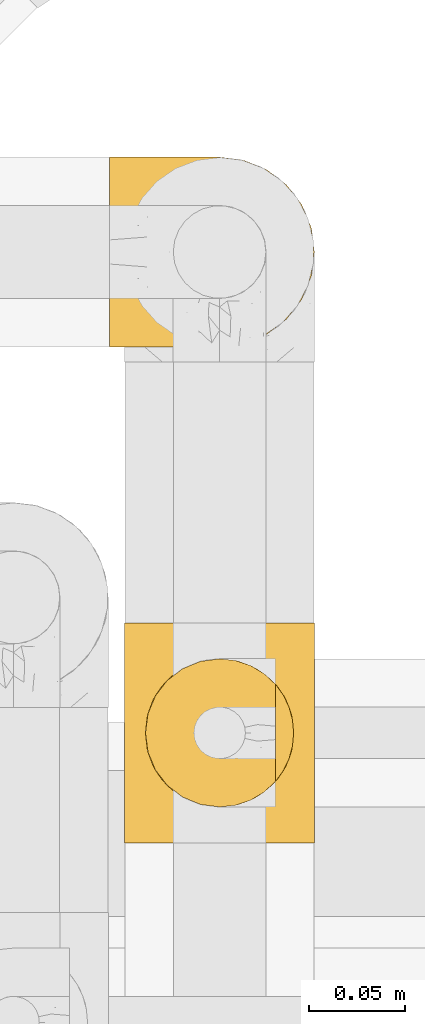
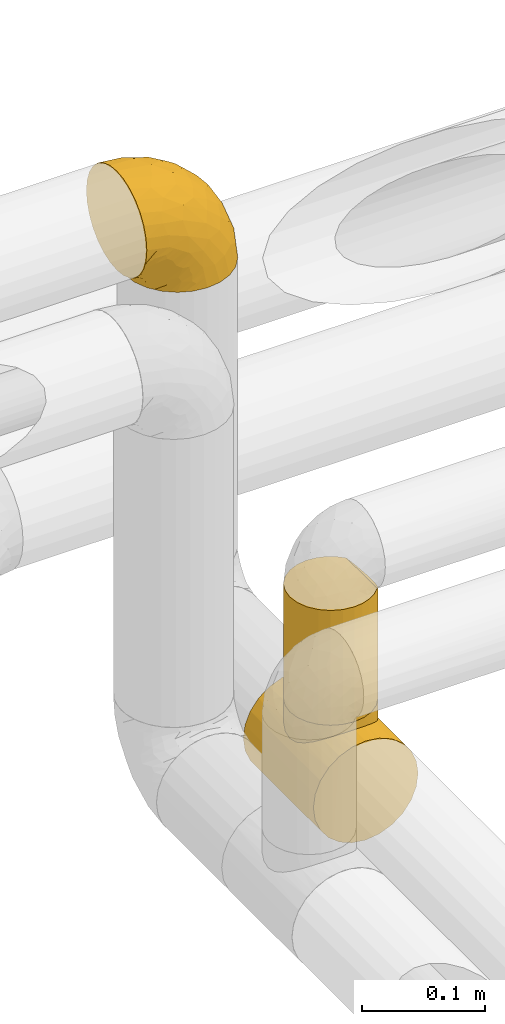
# One storey, part 373 of 827: 3 coverings.
"""IFC2X3 building model written with IfcOpenShell, lengths in millimetres."""

from ifc_helpers import new_model, entity, si_unit, converted_unit, derived_unit, direction, frame, origin, place, context, subcontext, project, spatial, faceted_brep, element, save


model = new_model("IFC2X3")

# Units and contexts
model_context = context("Model", 3, precision=0.01, world=origin(), true_north=direction((6.12303176911189e-17, 1.0)))
body_context = subcontext(model_context, "Body", "Model", "MODEL_VIEW")
ifc_project = project(units=[si_unit("LENGTHUNIT", "METRE", prefix="MILLI"), si_unit("AREAUNIT", "SQUARE_METRE"), si_unit("VOLUMEUNIT", "CUBIC_METRE"), converted_unit("PLANEANGLEUNIT", "DEGREE", entity("IfcRatioMeasure", 0.0174532925199433), si_unit("PLANEANGLEUNIT", "RADIAN"), dimensions=[0, 0, 0, 0, 0, 0, 0]), si_unit("MASSUNIT", "GRAM", prefix="KILO"), derived_unit("MASSDENSITYUNIT", [(si_unit("MASSUNIT", "GRAM", prefix="KILO"), 1), (si_unit("LENGTHUNIT", "METRE"), -3)]), derived_unit("MOMENTOFINERTIAUNIT", [(si_unit("LENGTHUNIT", "METRE"), 4)]), si_unit("TIMEUNIT", "SECOND"), si_unit("FREQUENCYUNIT", "HERTZ"), si_unit("THERMODYNAMICTEMPERATUREUNIT", "DEGREE_CELSIUS"), derived_unit("THERMALTRANSMITTANCEUNIT", [(si_unit("MASSUNIT", "GRAM", prefix="KILO"), 1), (si_unit("THERMODYNAMICTEMPERATUREUNIT", "KELVIN"), -1), (si_unit("TIMEUNIT", "SECOND"), -3)]), derived_unit("VOLUMETRICFLOWRATEUNIT", [(si_unit("LENGTHUNIT", "METRE"), 3), (si_unit("TIMEUNIT", "SECOND"), -1)]), derived_unit("MASSFLOWRATEUNIT", [(si_unit("MASSUNIT", "GRAM", prefix="KILO"), 1), (si_unit("TIMEUNIT", "SECOND"), -1)]), derived_unit("ROTATIONALFREQUENCYUNIT", [(si_unit("TIMEUNIT", "SECOND"), -1)]), si_unit("ELECTRICCURRENTUNIT", "AMPERE"), si_unit("ELECTRICVOLTAGEUNIT", "VOLT"), si_unit("POWERUNIT", "WATT"), si_unit("FORCEUNIT", "NEWTON", prefix="KILO"), si_unit("ILLUMINANCEUNIT", "LUX"), si_unit("LUMINOUSFLUXUNIT", "LUMEN"), si_unit("LUMINOUSINTENSITYUNIT", "CANDELA"), derived_unit("USERDEFINED", [(si_unit("MASSUNIT", "GRAM", prefix="KILO"), -1), (si_unit("LENGTHUNIT", "METRE"), -2), (si_unit("TIMEUNIT", "SECOND"), 3), (si_unit("LUMINOUSFLUXUNIT", "LUMEN"), 1)]), derived_unit("LINEARVELOCITYUNIT", [(si_unit("LENGTHUNIT", "METRE"), 1), (si_unit("TIMEUNIT", "SECOND"), -1)]), si_unit("PRESSUREUNIT", "PASCAL"), derived_unit("USERDEFINED", [(si_unit("LENGTHUNIT", "METRE"), -2), (si_unit("MASSUNIT", "GRAM", prefix="KILO"), 1), (si_unit("TIMEUNIT", "SECOND"), -2)]), derived_unit("LINEARFORCEUNIT", [(si_unit("MASSUNIT", "GRAM", prefix="KILO"), 1), (si_unit("LENGTHUNIT", "METRE"), 1), (si_unit("TIMEUNIT", "SECOND"), -2), (si_unit("LENGTHUNIT", "METRE"), -1)]), derived_unit("PLANARFORCEUNIT", [(si_unit("MASSUNIT", "GRAM", prefix="KILO"), 1), (si_unit("LENGTHUNIT", "METRE"), 1), (si_unit("TIMEUNIT", "SECOND"), -2), (si_unit("LENGTHUNIT", "METRE"), -2)])], contexts=[model_context])

# Site, building, storey
site_placement = place(None, origin())
site = spatial("IfcSite", under=ifc_project, at=site_placement, CompositionType="ELEMENT")
building_placement = place(site_placement, origin())
building = spatial("IfcBuilding", under=site, at=building_placement, CompositionType="ELEMENT")
storey_placement = place(building_placement, frame((0.0, 0.0, 28200.0)))
storey = spatial("IfcBuildingStorey", under=building, at=storey_placement, Name="08", CompositionType="ELEMENT", Elevation=28200.0)

# Coverings
covering_1_placement = place(storey_placement, frame((41417.62, 19064.74, 3341.3)))
element("IfcCovering", 1, at=covering_1_placement, inside=storey, Name=":ADSK_", ObjectType=":ADSK_", PredefinedType="INSULATION", context=body_context, shape_type="Brep", body=[
    faceted_brep([(1.6, 1.6, 58.6), (1.6, 2.83, 69.54), (1.6, 6.47, 79.93), (1.6, 12.32, 89.25), (1.6, 20.11, 97.03), (1.6, 29.43, 102.88), (1.6, 39.81, 106.51), (1.6, 50.75, 107.75), (1.6, 61.69, 106.51), (1.6, 72.08, 102.87), (1.6, 81.4, 97.02), (1.6, 89.18, 89.23), (1.6, 95.03, 79.91), (1.6, 98.66, 69.53), (1.6, 99.9, 58.6), (1.6, 99.25, 52.89), (1.6, 98.66, 47.65), (1.6, 96.84, 42.46), (1.6, 95.02, 37.26), (1.6, 89.17, 27.94), (1.6, 81.38, 20.16), (1.6, 72.06, 14.31), (1.6, 61.68, 10.68), (1.6, 50.75, 9.45), (1.6, 39.8, 10.68), (1.6, 29.41, 14.32), (1.6, 20.09, 20.17), (1.6, 12.31, 27.96), (1.6, 6.46, 37.28), (1.6, 4.64, 42.47), (1.6, 2.83, 47.66), (1.6, 2.24, 52.89), (1.6, 1.92, 55.75), (11.12, 63.47, 1.6), (16.03, 75.32, 1.6), (19.94, 80.41, 1.6), (23.84, 85.5, 1.6), (28.93, 89.4, 1.6), (34.02, 93.31, 1.6), (39.95, 95.77, 1.6), (45.87, 98.22, 1.6), (52.86, 99.14, 1.6), (55.73, 99.52, 1.6), (58.6, 99.9, 1.6), (71.32, 98.22, 1.6), (83.17, 93.31, 1.6), (93.35, 85.5, 1.6), (101.16, 75.32, 1.6), (106.07, 63.47, 1.6), (107.75, 50.75, 1.6), (106.07, 38.02, 1.6), (101.16, 26.17, 1.6), (93.35, 15.99, 1.6), (83.17, 8.18, 1.6), (71.32, 3.27, 1.6), (58.6, 1.6, 1.6), (52.86, 2.35, 1.6), (45.87, 3.27, 1.6), (39.95, 5.73, 1.6), (34.02, 8.18, 1.6), (28.93, 12.09, 1.6), (23.84, 15.99, 1.6), (19.94, 21.08, 1.6), (16.03, 26.17, 1.6), (11.12, 38.02, 1.6), (9.45, 50.75, 1.6), (81.82, 42.18, 69.96), (84.02, 28.42, 59.59), (93.05, 37.78, 51.96), (102.55, 50.75, 34.4), (104.83, 42.85, 23.37), (105.83, 50.75, 13.68), (91.87, 24.75, 41.52), (101.74, 33.81, 26.26), (97.07, 22.57, 20.18), (38.45, 7.18, 72.33), (22.17, 2.73, 65.88), (42.04, 3.09, 57.55), (77.69, 6.92, 23.76), (75.76, 11.58, 46.5), (62.11, 5.17, 46.57), (66.08, 2.71, 21.17), (54.26, 1.6, 23.41), (55.35, 1.6, 17.92), (56.44, 1.6, 12.43), (56.98, 1.6, 9.72), (57.52, 1.6, 7.01), (87.84, 14.18, 26.77), (19.41, 5.88, 76.59), (48.89, 41.06, 95.55), (26.34, 36.25, 102.57), (44.55, 28.62, 92.89), (23.41, 1.6, 54.26), (28.03, 1.6, 51.17), (32.65, 1.6, 48.08), (37.28, 1.6, 44.99), (41.9, 1.6, 41.9), (20.6, 10.85, 85.16), (63.36, 38.35, 85.97), (62.21, 9.6, 59.58), (19.94, 26.24, 99.5), (13.68, 50.75, 105.83), (80.85, 19.31, 53.59), (66.53, 16.41, 67.0), (71.06, 24.56, 71.56), (63.99, 50.75, 87.47), (75.73, 50.75, 75.73), (26.77, 18.47, 92.24), (4.31, 1.6, 58.06), (7.01, 1.6, 57.52), (12.43, 1.6, 56.44), (17.92, 1.6, 55.35), (43.43, 14.36, 81.33), (56.23, 20.64, 80.35), (54.97, 2.32, 39.44), (34.4, 50.75, 102.55), (44.99, 1.6, 37.28), (48.08, 1.6, 32.65), (51.17, 1.6, 28.03), (87.47, 50.75, 63.99), (74.55, 33.88, 74.55), (60.86, 29.24, 83.62), (49.19, 50.75, 95.01), (95.01, 50.75, 49.19), (10.27, 2.8, 46.96), (48.79, 2.48, 8.77), (45.16, 2.7, 18.28), (44.99, 3.2, 11.68), (6.17, 32.98, 11.79), (7.65, 24.67, 15.69), (21.59, 2.95, 42.49), (19.96, 2.19, 47.41), (21.0, 17.92, 7.94), (27.2, 12.02, 9.27), (14.83, 25.73, 7.98), (19.7, 16.63, 13.4), (10.93, 25.6, 13.04), (9.63, 36.72, 7.36), (19.97, 10.66, 23.46), (21.13, 6.87, 30.46), (14.14, 11.12, 26.54), (30.2, 10.31, 6.76), (8.12, 12.84, 26.46), (9.93, 17.38, 20.77), (24.62, 9.74, 20.68), (11.87, 4.63, 40.26), (7.15, 50.75, 7.15), (5.32, 42.52, 9.28), (26.68, 3.12, 38.78), (13.92, 17.58, 18.27), (30.67, 3.97, 31.78), (36.65, 5.94, 12.75), (42.89, 2.73, 22.96), (34.04, 6.23, 17.55), (36.6, 3.45, 27.63), (26.41, 10.84, 15.23), (10.07, 7.98, 33.25), (15.83, 7.33, 32.43), (41.99, 2.39, 27.9), (14.83, 75.76, 7.97), (26.4, 90.65, 15.22), (21.01, 83.57, 7.93), (19.71, 84.85, 13.38), (5.72, 71.05, 13.12), (21.6, 98.54, 42.49), (19.96, 99.3, 47.4), (28.03, 99.9, 51.17), (11.87, 96.86, 40.24), (9.93, 84.1, 20.76), (58.06, 99.9, 4.31), (56.44, 99.9, 12.43), (57.52, 99.9, 7.01), (8.13, 88.63, 26.44), (14.15, 90.36, 26.52), (44.99, 98.29, 11.68), (36.65, 95.55, 12.75), (27.21, 89.47, 9.27), (34.04, 95.26, 17.55), (30.2, 91.18, 6.76), (10.06, 93.49, 33.21), (15.83, 94.15, 32.41), (48.79, 99.01, 8.77), (42.89, 98.76, 22.96), (45.38, 98.85, 18.48), (12.43, 99.9, 56.44), (10.28, 98.69, 46.95), (9.64, 64.78, 7.36), (55.35, 99.9, 17.92), (54.26, 99.9, 23.41), (6.05, 62.91, 9.85), (7.01, 99.9, 57.52), (9.72, 99.9, 56.98), (32.65, 99.9, 48.08), (26.68, 98.37, 38.78), (13.92, 83.9, 18.25), (37.28, 99.9, 44.99), (30.66, 97.51, 31.74), (21.14, 94.62, 30.45), (36.59, 98.04, 27.63), (24.6, 91.73, 20.65), (17.92, 99.9, 55.35), (23.41, 99.9, 54.26), (10.93, 75.87, 13.03), (19.97, 90.83, 23.44), (41.99, 99.1, 27.9), (48.08, 99.9, 32.65), (51.17, 99.9, 28.03), (44.99, 99.9, 37.28), (41.9, 99.9, 41.9), (55.26, 99.09, 39.74), (104.83, 58.64, 23.37), (87.84, 87.31, 26.77), (75.91, 89.93, 46.18), (80.84, 82.22, 53.54), (91.87, 76.74, 41.53), (83.98, 73.12, 59.61), (19.16, 95.54, 76.79), (22.37, 98.7, 66.11), (66.08, 98.79, 21.17), (93.05, 63.71, 51.96), (101.74, 67.68, 26.26), (97.07, 78.92, 20.18), (77.69, 94.57, 23.76), (44.55, 72.88, 92.88), (26.34, 65.25, 102.57), (48.9, 60.44, 95.54), (70.99, 76.94, 71.63), (74.55, 67.61, 74.55), (37.8, 94.38, 72.51), (63.4, 63.11, 85.95), (81.82, 59.31, 69.96), (26.77, 83.03, 92.23), (20.6, 90.66, 85.15), (56.15, 80.8, 80.45), (60.85, 72.22, 83.65), (42.06, 98.39, 57.57), (57.03, 92.31, 63.68), (19.94, 75.27, 99.49), (43.59, 87.15, 81.23), (62.61, 96.03, 47.07), (66.52, 85.1, 66.99)], [[[0, 1, 2, 3, 4, 5, 6, 7, 8, 9, 10, 11, 12, 13, 14, 15, 16, 17, 18, 19, 20, 21, 22, 23, 24, 25, 26, 27, 28, 29, 30, 31, 32]], [[33, 34, 35, 36, 37, 38, 39, 40, 41, 42, 43, 44, 45, 46, 47, 48, 49, 50, 51, 52, 53, 54, 55, 56, 57, 58, 59, 60, 61, 62, 63, 64, 65]], [[66, 67, 68]], [[69, 70, 71]], [[68, 72, 73]], [[73, 72, 74]], [[75, 76, 77]], [[78, 79, 80]], [[51, 50, 73]], [[81, 82, 83, 84, 85, 86, 55]], [[52, 87, 53]], [[74, 52, 51]], [[2, 1, 88]], [[89, 90, 91]], [[77, 92, 93, 94, 95, 96]], [[55, 54, 81]], [[78, 53, 87]], [[5, 90, 6]], [[88, 76, 75]], [[97, 3, 2]], [[89, 91, 98]], [[99, 80, 79]], [[90, 5, 100]], [[74, 87, 52]], [[100, 5, 4]], [[90, 101, 6]], [[79, 102, 103]], [[102, 67, 104]], [[105, 98, 106]], [[107, 4, 3]], [[76, 0, 108, 109, 110, 111, 92]], [[107, 112, 113]], [[114, 77, 96]], [[89, 115, 90]], [[114, 96, 116, 117, 118, 82]], [[75, 97, 88]], [[119, 66, 68]], [[50, 71, 70]], [[100, 91, 90]], [[99, 77, 80]], [[102, 104, 103]], [[97, 107, 3]], [[80, 81, 78]], [[107, 97, 112]], [[68, 73, 70]], [[66, 98, 120]], [[78, 81, 54]], [[114, 81, 80]], [[53, 78, 54]], [[78, 87, 79]], [[102, 87, 72]], [[79, 103, 99]], [[4, 107, 100]], [[91, 100, 107]], [[88, 97, 2]], [[112, 97, 75]], [[99, 112, 75]], [[103, 104, 113]], [[91, 121, 98]], [[89, 105, 122, 115]], [[101, 90, 115]], [[101, 7, 6]], [[88, 1, 76]], [[0, 76, 1]], [[92, 77, 76]], [[73, 74, 51]], [[87, 74, 72]], [[81, 114, 82]], [[77, 114, 80]], [[87, 102, 79]], [[67, 102, 72]], [[68, 67, 72]], [[67, 120, 104]], [[120, 121, 104]], [[104, 121, 113]], [[121, 120, 98]], [[91, 107, 113]], [[91, 113, 121]], [[103, 113, 112]], [[106, 98, 66]], [[105, 89, 98]], [[106, 66, 119]], [[67, 66, 120]], [[68, 69, 123, 119]], [[50, 49, 71]], [[50, 70, 73]], [[112, 99, 103]], [[77, 99, 75]], [[69, 68, 70]], [[29, 124, 110]], [[84, 83, 125]], [[126, 82, 118]], [[59, 58, 127]], [[25, 128, 129]], [[130, 93, 131]], [[132, 62, 133]], [[134, 135, 136]], [[137, 65, 64]], [[64, 134, 137]], [[138, 139, 140]], [[111, 110, 124, 92]], [[134, 136, 137]], [[134, 64, 63]], [[141, 61, 60]], [[125, 58, 57]], [[142, 143, 140]], [[142, 26, 143]], [[127, 83, 82]], [[28, 124, 29]], [[108, 0, 32, 31, 30, 110, 109]], [[30, 29, 110]], [[135, 144, 138]], [[28, 145, 124]], [[57, 56, 55, 86, 85, 84]], [[146, 147, 23]], [[24, 23, 147]], [[25, 143, 26]], [[95, 94, 148]], [[24, 128, 25]], [[149, 138, 143]], [[124, 145, 131]], [[127, 58, 125]], [[150, 148, 139]], [[127, 126, 151]], [[151, 59, 127]], [[152, 151, 126]], [[153, 154, 155]], [[153, 133, 141]], [[145, 28, 27]], [[142, 156, 27]], [[157, 148, 130]], [[61, 133, 62]], [[134, 132, 135]], [[147, 128, 24]], [[65, 137, 146]], [[146, 137, 147]], [[128, 137, 136]], [[137, 128, 147]], [[128, 136, 129]], [[149, 129, 136]], [[25, 129, 143]], [[158, 152, 117]], [[152, 118, 117]], [[153, 151, 152]], [[158, 116, 154]], [[144, 150, 138]], [[153, 152, 158]], [[133, 153, 155]], [[133, 155, 132]], [[141, 60, 151]], [[135, 132, 155]], [[134, 63, 132]], [[144, 135, 155]], [[135, 138, 149]], [[155, 154, 144]], [[150, 154, 96]], [[154, 150, 144]], [[148, 94, 130]], [[82, 126, 127]], [[118, 152, 126]], [[150, 96, 95]], [[139, 148, 157]], [[150, 95, 148]], [[93, 92, 131]], [[130, 145, 156]], [[130, 94, 93]], [[84, 125, 57]], [[127, 125, 83]], [[140, 139, 157]], [[150, 139, 138]], [[140, 157, 142]], [[138, 140, 143]], [[156, 142, 157]], [[27, 26, 142]], [[130, 156, 157]], [[145, 27, 156]], [[132, 63, 62]], [[124, 131, 92]], [[130, 131, 145]], [[129, 149, 143]], [[135, 149, 136]], [[153, 141, 151]], [[59, 151, 60]], [[133, 61, 141]], [[116, 96, 154]], [[153, 158, 154]], [[158, 117, 116]], [[34, 33, 159]], [[160, 161, 162]], [[22, 21, 163]], [[164, 165, 166]], [[19, 18, 167]], [[168, 21, 20]], [[169, 43, 42, 41, 40, 170, 171]], [[172, 173, 168]], [[174, 38, 175]], [[176, 177, 178]], [[179, 164, 180]], [[40, 181, 170]], [[182, 183, 175]], [[17, 184, 185]], [[65, 146, 186]], [[187, 174, 188]], [[23, 22, 189]], [[174, 39, 38]], [[15, 14, 190, 191, 184, 16]], [[181, 40, 39]], [[192, 193, 164]], [[194, 163, 168]], [[33, 186, 159]], [[180, 173, 172]], [[195, 196, 193]], [[18, 185, 167]], [[173, 180, 197]], [[198, 199, 196]], [[200, 201, 185, 184]], [[184, 17, 16]], [[18, 17, 185]], [[202, 159, 186]], [[194, 168, 203]], [[189, 163, 202]], [[204, 205, 182]], [[187, 181, 174]], [[160, 177, 176]], [[206, 183, 182]], [[206, 182, 205]], [[201, 165, 185]], [[165, 164, 167]], [[172, 179, 180]], [[202, 194, 162]], [[176, 161, 160]], [[65, 186, 33]], [[163, 189, 22]], [[175, 177, 182]], [[174, 183, 188]], [[177, 198, 204]], [[199, 160, 162]], [[198, 207, 204]], [[175, 38, 37]], [[198, 177, 160]], [[178, 177, 175]], [[176, 35, 161]], [[34, 159, 161]], [[162, 161, 159]], [[202, 162, 159]], [[199, 162, 203]], [[196, 199, 203]], [[198, 160, 199]], [[193, 197, 180]], [[208, 198, 196]], [[188, 183, 206]], [[175, 183, 174]], [[193, 192, 195]], [[195, 208, 196]], [[197, 196, 203]], [[180, 164, 193]], [[168, 163, 21]], [[166, 165, 201]], [[166, 192, 164]], [[189, 202, 186]], [[186, 146, 189]], [[23, 189, 146]], [[174, 181, 39]], [[170, 181, 187]], [[196, 197, 193]], [[173, 203, 168]], [[203, 173, 197]], [[172, 168, 20]], [[20, 19, 172]], [[179, 172, 19]], [[19, 167, 179]], [[164, 179, 167]], [[35, 176, 36]], [[35, 34, 161]], [[185, 165, 167]], [[162, 194, 203]], [[163, 194, 202]], [[176, 178, 36]], [[37, 36, 178]], [[175, 37, 178]], [[177, 204, 182]], [[207, 198, 208]], [[207, 205, 204]], [[209, 188, 206, 205, 207, 208]], [[48, 210, 71]], [[211, 212, 213]], [[214, 213, 215]], [[216, 217, 13]], [[218, 43, 169, 171, 170, 187, 188]], [[219, 220, 214]], [[47, 46, 221]], [[210, 48, 220]], [[211, 222, 212]], [[222, 45, 44]], [[221, 220, 47]], [[47, 220, 48]], [[221, 211, 214]], [[223, 224, 225]], [[211, 46, 45]], [[226, 227, 215]], [[43, 218, 44]], [[217, 216, 228]], [[227, 229, 230]], [[14, 13, 217]], [[224, 9, 8]], [[10, 231, 11]], [[11, 232, 12]], [[233, 223, 234]], [[235, 208, 195, 192, 166, 201]], [[236, 235, 228]], [[222, 44, 218]], [[106, 230, 229]], [[224, 237, 9]], [[232, 238, 228]], [[9, 237, 10]], [[115, 224, 101]], [[239, 235, 236]], [[232, 11, 231]], [[223, 231, 237]], [[224, 8, 101]], [[223, 229, 234]], [[225, 115, 122, 105]], [[216, 12, 232]], [[209, 235, 239]], [[210, 219, 69]], [[219, 214, 215]], [[230, 119, 219]], [[209, 218, 188]], [[239, 212, 222]], [[239, 222, 218]], [[45, 222, 211]], [[236, 212, 239]], [[213, 212, 240]], [[223, 237, 224]], [[231, 10, 237]], [[238, 232, 231]], [[216, 232, 228]], [[233, 231, 223]], [[236, 238, 240]], [[115, 225, 224]], [[234, 229, 227]], [[8, 7, 101]], [[235, 209, 208]], [[218, 209, 239]], [[217, 228, 235]], [[13, 12, 216]], [[235, 201, 217]], [[217, 201, 200, 184, 191, 190, 14]], [[211, 221, 46]], [[220, 221, 214]], [[71, 210, 69]], [[71, 49, 48]], [[219, 210, 220]], [[226, 215, 213]], [[211, 213, 214]], [[226, 213, 240]], [[215, 227, 230]], [[233, 240, 238]], [[234, 227, 226]], [[233, 234, 226]], [[229, 223, 225]], [[240, 233, 226]], [[233, 238, 231]], [[225, 105, 229]], [[229, 105, 106]], [[106, 119, 230]], [[123, 69, 219, 119]], [[215, 230, 219]], [[238, 236, 228]], [[212, 236, 240]]]),
])
covering_2_placement = place(storey_placement, frame((41425.47, 18809.22, 2949.25)))
element("IfcCovering", 2, at=covering_2_placement, inside=storey, Name=":ADSK_", ObjectType=":ADSK_", PredefinedType="INSULATION", context=body_context, shape_type="Brep", body=[
    faceted_brep([(26.17, 0.0, 8.18), (38.02, 0.0, 3.27), (50.75, 0.0, 1.6), (63.47, 0.0, 3.27), (75.32, 0.0, 8.18), (85.5, 0.0, 15.99), (93.31, 0.0, 26.17), (98.22, 0.0, 38.02), (99.9, 0.0, 50.75), (98.22, 0.0, 63.47), (93.31, 0.0, 75.32), (85.5, 0.0, 85.5), (80.41, 0.0, 89.4), (75.32, 0.0, 93.31), (69.39, 0.0, 95.77), (63.47, 0.0, 98.22), (60.29, 0.0, 98.64), (57.11, 0.0, 99.06), (53.93, 0.0, 99.48), (50.75, 0.0, 99.9), (47.57, 0.0, 99.48), (44.38, 0.0, 99.06), (41.2, 0.0, 98.64), (38.02, 0.0, 98.22), (32.1, 0.0, 95.77), (26.17, 0.0, 93.31), (21.08, 0.0, 89.4), (15.99, 0.0, 85.5), (8.18, 0.0, 75.32), (3.27, 0.0, 63.47), (1.6, 0.0, 50.75), (3.27, 0.0, 38.02), (8.18, 0.0, 26.17), (15.99, 0.0, 15.99), (98.22, 114.0, 38.02), (93.31, 114.0, 26.17), (85.5, 114.0, 15.99), (75.32, 114.0, 8.18), (63.47, 114.0, 3.27), (50.75, 114.0, 1.6), (38.02, 114.0, 3.27), (26.17, 114.0, 8.18), (15.99, 114.0, 15.99), (8.18, 114.0, 26.17), (3.27, 114.0, 38.02), (1.6, 114.0, 50.75), (3.27, 114.0, 63.47), (8.18, 114.0, 75.32), (15.99, 114.0, 85.5), (21.08, 114.0, 89.4), (26.17, 114.0, 93.31), (32.1, 114.0, 95.77), (38.02, 114.0, 98.22), (41.2, 114.0, 98.64), (44.38, 114.0, 99.06), (47.57, 114.0, 99.48), (50.75, 114.0, 99.9), (53.93, 114.0, 99.48), (57.11, 114.0, 99.06), (60.29, 114.0, 98.64), (63.47, 114.0, 98.22), (69.39, 114.0, 95.77), (75.32, 114.0, 93.31), (80.41, 114.0, 89.4), (85.5, 114.0, 85.5), (93.31, 114.0, 75.32), (98.22, 114.0, 63.47), (99.9, 114.0, 50.75), (80.86, 80.91, 89.59), (85.26, 73.95, 85.74), (75.08, 86.77, 93.45), (67.99, 22.63, 96.77), (88.15, 65.92, 82.63), (89.2, 57.0, 81.36), (88.15, 48.08, 82.63), (50.75, 18.55, 99.9), (50.75, 95.45, 99.9), (80.86, 33.09, 89.59), (85.26, 40.05, 85.74), (75.08, 27.23, 93.45), (67.99, 91.37, 96.77), (63.86, 21.12, 97.92), (59.73, 94.39, 99.07), (55.24, 94.92, 99.48), (63.86, 92.88, 97.92), (59.73, 19.61, 99.07), (55.24, 19.08, 99.48), (46.25, 94.92, 99.48), (37.63, 92.88, 97.92), (26.41, 86.77, 93.45), (41.76, 94.39, 99.07), (33.5, 91.37, 96.77), (37.63, 21.12, 97.92), (41.76, 19.61, 99.07), (46.25, 19.08, 99.48), (26.41, 27.23, 93.45), (33.5, 22.63, 96.77), (20.63, 33.09, 89.59), (20.63, 80.91, 89.59), (16.23, 73.95, 85.74), (13.34, 65.92, 82.63), (12.3, 57.0, 81.36), (16.23, 40.05, 85.74), (13.34, 48.08, 82.63), (89.2, 57.0, 107.75), (87.89, 66.95, 107.75), (84.04, 76.22, 107.75), (77.93, 84.19, 107.75), (69.97, 90.3, 107.75), (60.7, 94.14, 107.75), (50.75, 95.45, 107.75), (40.79, 94.14, 107.75), (31.52, 90.3, 107.75), (23.56, 84.19, 107.75), (17.45, 76.22, 107.75), (13.61, 66.95, 107.75), (12.3, 57.0, 107.75), (13.61, 47.05, 107.75), (17.45, 37.77, 107.75), (23.56, 29.81, 107.75), (31.52, 23.7, 107.75), (40.79, 19.86, 107.75), (50.75, 18.55, 107.75), (60.7, 19.86, 107.75), (69.97, 23.7, 107.75), (77.93, 29.81, 107.75), (84.04, 37.77, 107.75), (87.89, 47.05, 107.75)], [[[0, 1, 2, 3, 4, 5, 6, 7, 8, 9, 10, 11, 12, 13, 14, 15, 16, 17, 18, 19, 20, 21, 22, 23, 24, 25, 26, 27, 28, 29, 30, 31, 32, 33]], [[34, 35, 36, 37, 38, 39, 40, 41, 42, 43, 44, 45, 46, 47, 48, 49, 50, 51, 52, 53, 54, 55, 56, 57, 58, 59, 60, 61, 62, 63, 64, 65, 66, 67]], [[37, 36, 5, 4]], [[2, 39, 38, 3]], [[38, 37, 4, 3]], [[6, 35, 34, 7]], [[7, 34, 67, 8]], [[5, 36, 35, 6]], [[66, 9, 8, 67]], [[65, 10, 9, 66]], [[64, 68, 69]], [[63, 62, 70]], [[71, 15, 14]], [[69, 72, 64]], [[68, 64, 63]], [[64, 72, 65]], [[72, 73, 65]], [[74, 11, 10]], [[18, 75, 19]], [[76, 57, 56]], [[77, 11, 78]], [[78, 11, 74]], [[79, 12, 77]], [[74, 10, 73]], [[73, 10, 65]], [[70, 61, 80]], [[61, 70, 62]], [[80, 61, 60]], [[15, 71, 81]], [[82, 59, 58]], [[83, 57, 76]], [[84, 59, 82]], [[82, 58, 83]], [[83, 58, 57]], [[60, 84, 80]], [[17, 85, 86]], [[79, 13, 12]], [[59, 84, 60]], [[79, 14, 13]], [[14, 79, 71]], [[85, 17, 16]], [[77, 12, 11]], [[18, 17, 86]], [[15, 81, 16]], [[16, 81, 85]], [[75, 18, 86]], [[68, 63, 70]], [[54, 87, 55]], [[53, 52, 88]], [[76, 55, 87]], [[50, 89, 51]], [[54, 90, 87]], [[91, 51, 89]], [[91, 52, 51]], [[88, 90, 53]], [[92, 22, 93]], [[93, 21, 94]], [[75, 20, 19]], [[55, 76, 56]], [[20, 75, 94]], [[95, 25, 24]], [[90, 54, 53]], [[24, 23, 96]], [[95, 97, 26]], [[96, 23, 92]], [[89, 49, 98]], [[89, 50, 49]], [[94, 21, 20]], [[98, 48, 99]], [[48, 98, 49]], [[99, 48, 100]], [[52, 91, 88]], [[28, 47, 46, 29]], [[101, 100, 47]], [[47, 100, 48]], [[46, 45, 30, 29]], [[93, 22, 21]], [[102, 103, 27]], [[95, 24, 96]], [[26, 25, 95]], [[27, 97, 102]], [[103, 28, 27]], [[22, 92, 23]], [[101, 28, 103]], [[101, 47, 28]], [[97, 27, 26]], [[31, 44, 43, 32]], [[32, 43, 42, 33]], [[45, 44, 31, 30]], [[0, 41, 40, 1]], [[1, 40, 39, 2]], [[33, 42, 41, 0]], [[104, 105, 106, 107, 108, 109, 110, 111, 112, 113, 114, 115, 116, 117, 118, 119, 120, 121, 122, 123, 124, 125, 126, 127]], [[82, 110, 109]], [[80, 109, 108]], [[110, 82, 83, 76]], [[70, 80, 108]], [[109, 80, 84, 82]], [[108, 107, 70]], [[107, 106, 68]], [[106, 105, 69]], [[72, 105, 104]], [[68, 106, 69]], [[72, 69, 105]], [[73, 72, 104]], [[107, 68, 70]], [[74, 104, 127]], [[78, 127, 126]], [[73, 104, 74]], [[74, 127, 78]], [[126, 77, 78]], [[126, 125, 77]], [[79, 125, 124]], [[124, 123, 71]], [[122, 85, 123]], [[71, 79, 124]], [[122, 75, 86, 85]], [[123, 85, 81, 71]], [[125, 79, 77]], [[93, 122, 121]], [[96, 121, 120]], [[122, 93, 94, 75]], [[95, 96, 120]], [[121, 96, 92, 93]], [[120, 119, 95]], [[97, 119, 118]], [[118, 117, 102]], [[116, 103, 117]], [[97, 118, 102]], [[103, 102, 117]], [[101, 103, 116]], [[119, 97, 95]], [[100, 116, 115]], [[99, 115, 114]], [[101, 116, 100]], [[100, 115, 99]], [[114, 98, 99]], [[114, 113, 98]], [[89, 113, 112]], [[112, 111, 91]], [[110, 90, 111]], [[91, 89, 112]], [[110, 76, 87, 90]], [[111, 90, 88, 91]], [[113, 89, 98]]]),
])
covering_3_placement = place(storey_placement, frame((41436.22, 18826.22, 3057.0)))
element("IfcCovering", 3, at=covering_3_placement, inside=storey, Name=":ADSK_", ObjectType=":ADSK_", PredefinedType="INSULATION", context=body_context, shape_type="Brep", body=[
    faceted_brep([(2.9, 30.06, 0.0), (1.6, 40.0, 0.0), (2.9, 49.93, 0.0), (6.74, 59.2, 0.0), (12.84, 67.15, 0.0), (20.8, 73.25, 0.0), (30.06, 77.09, 0.0), (40.0, 78.4, 0.0), (49.93, 77.09, 0.0), (59.2, 73.25, 0.0), (67.15, 67.15, 0.0), (73.25, 59.2, 0.0), (77.09, 49.93, 0.0), (78.4, 40.0, 0.0), (77.09, 30.06, 0.0), (73.25, 20.8, 0.0), (67.15, 12.84, 0.0), (59.2, 6.74, 0.0), (49.93, 2.9, 0.0), (40.0, 1.6, 0.0), (30.06, 2.9, 0.0), (20.8, 6.74, 0.0), (12.84, 12.84, 0.0), (6.74, 20.8, 0.0), (2.9, 49.93, 113.9), (1.6, 40.0, 113.9), (2.9, 30.06, 113.9), (6.74, 20.8, 113.9), (12.84, 12.84, 113.9), (20.8, 6.74, 113.9), (30.06, 2.9, 113.9), (40.0, 1.6, 113.9), (48.2, 2.48, 113.9), (56.01, 5.09, 113.9), (63.08, 9.31, 113.9), (69.1, 14.94, 113.9), (69.1, 65.05, 113.9), (63.08, 70.68, 113.9), (56.01, 74.9, 113.9), (48.2, 77.51, 113.9), (40.0, 78.4, 113.9), (30.06, 77.09, 113.9), (20.8, 73.25, 113.9), (12.84, 67.15, 113.9), (6.74, 59.2, 113.9), (73.07, 59.51, 109.93), (76.0, 53.36, 107.0), (77.79, 46.78, 105.2), (78.4, 40.0, 104.6), (77.79, 33.21, 105.2), (76.0, 26.63, 107.0), (73.07, 20.48, 109.93)], [[[0, 1, 2, 3, 4, 5, 6, 7, 8, 9, 10, 11, 12, 13, 14, 15, 16, 17, 18, 19, 20, 21, 22, 23]], [[24, 25, 26, 27, 28, 29, 30, 31, 32, 33, 34, 35, 36, 37, 38, 39, 40, 41, 42, 43, 44]], [[40, 39, 7]], [[38, 37, 9]], [[39, 38, 8]], [[8, 7, 39]], [[9, 8, 38]], [[37, 10, 9]], [[37, 36, 10]], [[36, 45, 11]], [[46, 47, 12]], [[45, 46, 11]], [[11, 46, 12]], [[13, 12, 47]], [[48, 13, 47]], [[36, 11, 10]], [[49, 50, 14]], [[51, 35, 15]], [[50, 51, 15]], [[48, 49, 13]], [[13, 49, 14]], [[50, 15, 14]], [[35, 16, 15]], [[17, 34, 33]], [[18, 33, 32]], [[19, 32, 31]], [[16, 34, 17]], [[17, 33, 18]], [[32, 19, 18]], [[34, 16, 35]], [[20, 19, 31, 30]], [[21, 20, 30, 29]], [[29, 28, 22, 21]], [[0, 23, 27, 26]], [[1, 0, 26, 25]], [[28, 27, 23, 22]], [[2, 1, 25, 24]], [[3, 2, 24, 44]], [[44, 43, 4, 3]], [[6, 5, 42, 41]], [[7, 6, 41, 40]], [[43, 42, 5, 4]], [[35, 51, 50, 49, 48, 47, 46, 45, 36]]]),
])

save(model, "model.ifc")
